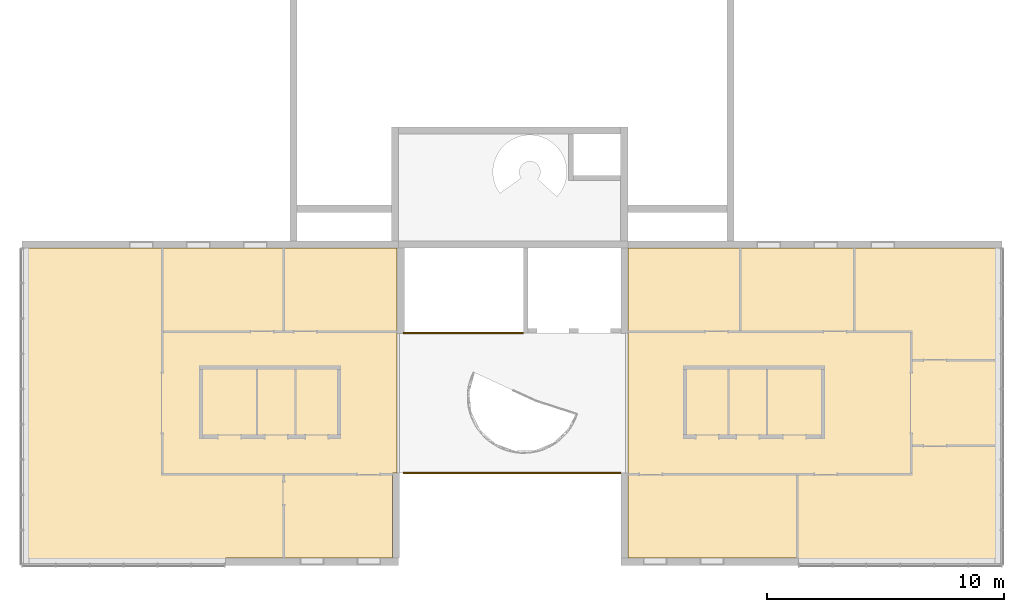
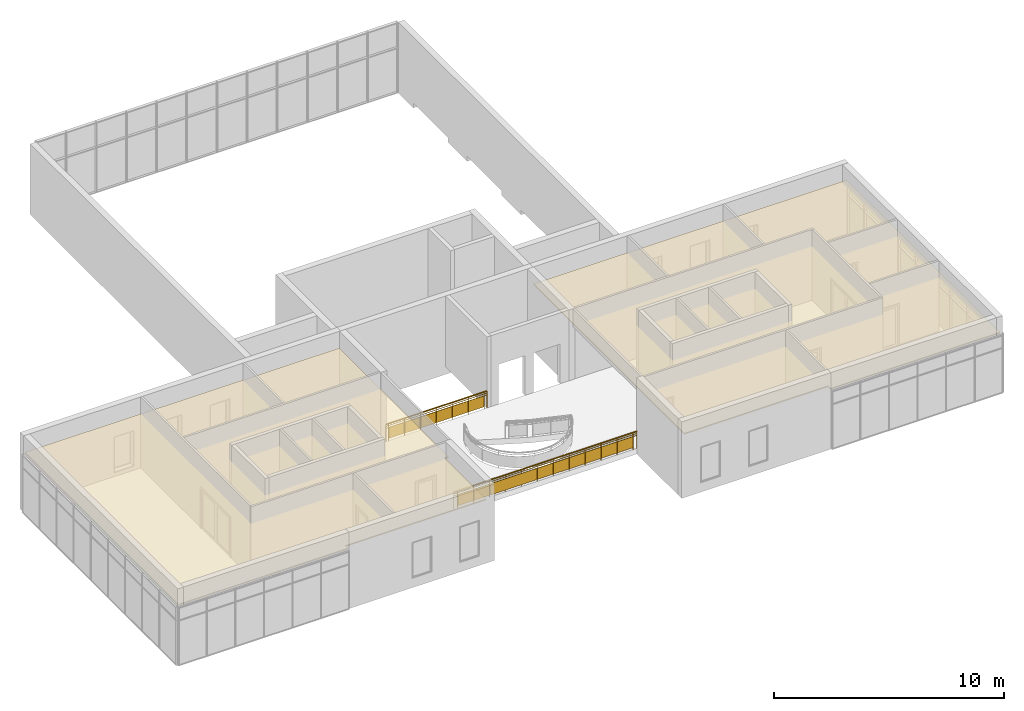
# One storey, part 13 of 13: 2 railings, 1 covering.
"""IFC2X3 building model written with IfcOpenShell, lengths in millimetres."""

from ifc_helpers import new_model, entity, si_unit, converted_unit, derived_unit, direction, frame, frame_2d, origin, place, context, subcontext, project, spatial, polyline, rectangle, outline, extrude, material, material_list, layer, layer_set, layer_usage, element, save


model = new_model("IFC2X3")

# Units and contexts
model_context = context("Model", 3, precision=0.01, world=origin(), true_north=direction((6.12303176911189e-17, 1.0)))
context_of_model = context(None, 3, precision=0.01, world=origin(), true_north=direction((6.12303176911189e-17, 1.0)))
body_context = subcontext(model_context, "Body", "Model", "MODEL_VIEW")
ifc_project = project(units=[si_unit("LENGTHUNIT", "METRE", prefix="MILLI"), si_unit("AREAUNIT", "SQUARE_METRE"), si_unit("VOLUMEUNIT", "CUBIC_METRE"), converted_unit("PLANEANGLEUNIT", "DEGREE", entity("IfcRatioMeasure", 0.0174532925199433), si_unit("PLANEANGLEUNIT", "RADIAN"), dimensions=[0, 0, 0, 0, 0, 0, 0]), si_unit("MASSUNIT", "GRAM", prefix="KILO"), si_unit("TIMEUNIT", "SECOND"), si_unit("FREQUENCYUNIT", "HERTZ"), si_unit("THERMODYNAMICTEMPERATUREUNIT", "DEGREE_CELSIUS"), derived_unit("THERMALTRANSMITTANCEUNIT", [(si_unit("MASSUNIT", "GRAM", prefix="KILO"), 1), (si_unit("THERMODYNAMICTEMPERATUREUNIT", "KELVIN"), -1), (si_unit("TIMEUNIT", "SECOND"), -3)]), derived_unit("VOLUMETRICFLOWRATEUNIT", [(si_unit("LENGTHUNIT", "METRE"), 3), (si_unit("TIMEUNIT", "SECOND"), -1)]), si_unit("ELECTRICCURRENTUNIT", "AMPERE"), si_unit("ELECTRICVOLTAGEUNIT", "VOLT"), si_unit("POWERUNIT", "WATT"), si_unit("FORCEUNIT", "NEWTON", prefix="KILO"), si_unit("ILLUMINANCEUNIT", "LUX"), si_unit("LUMINOUSFLUXUNIT", "LUMEN"), si_unit("LUMINOUSINTENSITYUNIT", "CANDELA"), si_unit("PRESSUREUNIT", "PASCAL")], contexts=[model_context, context_of_model])

# Site, building, storey
site_placement = place(None, origin())
site = spatial("IfcSite", under=ifc_project, at=site_placement, CompositionType="ELEMENT")
building_placement = place(site_placement, origin())
building = spatial("IfcBuilding", under=site, at=building_placement, CompositionType="ELEMENT")
storey_placement = place(building_placement, frame((0.0, 0.0, 3750.0)))
storey = spatial("IfcBuildingStorey", under=building, at=storey_placement, Name="02. 2 etg.", CompositionType="ELEMENT", Elevation=3750.00000000068)

# Covering
ifc_material_1 = material(Name="Metal Stud Layer")
ifc_layer_1 = layer(ifc_material_1, 45.0)
ifc_material_2 = material(Name="Gypsum Wall Board")
ifc_layer_2 = layer(ifc_material_2, 12.0)
ifc_layer_set = layer_set([ifc_layer_1, ifc_layer_2], Name="Compound Ceiling:Plain")
ifc_layer_usage = layer_usage(ifc_layer_set, "AXIS3", "NEGATIVE", 0.0)
covering_placement = place(storey_placement, frame((-165.0, -13365.0, 2800.0)))
element("IfcCovering", 1, at=covering_placement, inside=storey, material=ifc_layer_usage, Name="Compound Ceiling:Plain", ObjectType="Compound Ceiling:Plain", PredefinedType="CEILING", context=body_context, shape_type="SweptSolid", body=[
    extrude(outline(polyline([(-8073.33333333336, -8795.0), (7631.66666666668, -8795.0), (7631.66666666668, 4285.0), (441.666666666662, 4285.0), (441.666666666662, 4510.0), (-8073.33333333336, 4510.0), (-8073.33333333336, -8795.0)])), frame((33114.9023790161, 4510.0, 0.0), z_axis=(0.0, 0.0, 1.0), x_axis=(-1.0, 0.0, 0.0)), (0.0, 0.0, 1.0), 57.0),
    extrude(outline(polyline([(-6906.33333333331, -9423.33333333336), (8848.6666666667, -9423.33333333336), (8848.66666666668, 3656.66666666675), (8848.66666666668, 3881.6666666667), (343.66666666665, 3881.6666666667), (343.666666666652, 3656.6666666667), (-6710.33333333336, 3656.66666666667), (-6710.33333333335, 56.666666666597), (-6906.33333333334, 56.6666666665963), (-6906.33333333331, -9423.33333333336)])), frame((8848.66666666669, 3881.66666666673, 0.0), z_axis=(0.0, 0.0, 1.0), x_axis=(-1.0, 0.0, 0.0)), (0.0, 0.0, 1.0), 57.0),
])

# Railings
ifc_material_3 = material(Name="Metal - Stainless Steel,Polished")
ifc_material_4 = material(Name="Glass")
ifc_material_list_1 = material_list([ifc_material_3, ifc_material_4])
railing_1_placement = place(storey_placement, frame((15836.0, -3690.98603739636, 0.0)))
element("IfcRailing", 2, at=railing_1_placement, inside=storey, material=ifc_material_list_1, Name="Railing:Glass Panel - Bottom Fill", ObjectType="Railing:Glass Panel - Bottom Fill", PredefinedType="NOTDEFINED", context=body_context, shape_type="SweptSolid", body=[
    extrude(rectangle(XDim=50.0, YDim=11.9999999999994, at=frame_2d((2.71782596428238e-13, -1.0831335828243e-12), x_axis=(1.0, 0.0))), frame((140.948313566078, 40.9860373963539, 0.0), z_axis=(0.0, 0.0, 1.0), x_axis=(0.0, 1.0, 0.0)), (0.0, 0.0, 1.0), 869.84653257006),
    extrude(rectangle(XDim=4.99999999999995, YDim=799.999999999998, at=frame_2d((0.0, -1.08002495835535e-12), x_axis=(1.0, 0.0))), frame((540.948313566086, 45.2108474939677, 100.0), z_axis=(0.0, 0.0, 1.0), x_axis=(0.0, 1.0, 0.0)), (0.0, 0.0, 1.0), 580.0),
    extrude(rectangle(XDim=50.0, YDim=11.9999999999994, at=frame_2d((-2.71782596428238e-13, -1.0831335828243e-12), x_axis=(1.0, 0.0))), frame((940.94831356608, 40.9860373963523, 0.0), z_axis=(0.0, 0.0, 1.0), x_axis=(0.0, 1.0, 0.0)), (0.0, 0.0, 1.0), 869.84653257006),
    extrude(rectangle(XDim=4.99999999999995, YDim=799.999999999998, at=frame_2d((0.0, -1.08002495835535e-12), x_axis=(1.0, 0.0))), frame((1340.94831356609, 45.210847493965, 100.0), z_axis=(0.0, 0.0, 1.0), x_axis=(0.0, 1.0, 0.0)), (0.0, 0.0, 1.0), 580.0),
    extrude(rectangle(XDim=50.0, YDim=11.9999999999994, at=frame_2d((2.71782596428238e-13, -1.0831335828243e-12), x_axis=(1.0, 0.0))), frame((1740.94831356608, 40.986037396349, 0.0), z_axis=(0.0, 0.0, 1.0), x_axis=(0.0, 1.0, 0.0)), (0.0, 0.0, 1.0), 869.84653257006),
    extrude(rectangle(XDim=4.99999999999995, YDim=799.999999999998, at=frame_2d((-5.41344746807226e-13, -1.08002495835535e-12), x_axis=(1.0, 0.0))), frame((2140.94831356609, 45.2108474939634, 100.0), z_axis=(0.0, 0.0, 1.0), x_axis=(0.0, 1.0, 0.0)), (0.0, 0.0, 1.0), 580.0),
    extrude(rectangle(XDim=50.0, YDim=11.9999999999994, at=frame_2d((-2.71782596428238e-13, -1.0831335828243e-12), x_axis=(1.0, 0.0))), frame((2540.94831356608, 40.9860373963468, 0.0), z_axis=(0.0, 0.0, 1.0), x_axis=(0.0, 1.0, 0.0)), (0.0, 0.0, 1.0), 869.84653257006),
    extrude(rectangle(XDim=4.99999999999995, YDim=799.999999999998, at=frame_2d((0.0, -1.08002495835535e-12), x_axis=(1.0, 0.0))), frame((2940.94831356609, 45.2108474939602, 100.0), z_axis=(0.0, 0.0, 1.0), x_axis=(0.0, 1.0, 0.0)), (0.0, 0.0, 1.0), 580.0),
    extrude(rectangle(XDim=50.0, YDim=11.9999999999994, at=frame_2d((2.71782596428238e-13, -1.0831335828243e-12), x_axis=(1.0, 0.0))), frame((3340.94831356608, 40.9860373963436, 0.0), z_axis=(0.0, 0.0, 1.0), x_axis=(0.0, 1.0, 0.0)), (0.0, 0.0, 1.0), 869.84653257006),
    extrude(rectangle(XDim=4.99999999999995, YDim=799.999999999998, at=frame_2d((0.0, 2.1600499167107e-12), x_axis=(1.0, 0.0))), frame((3740.94831356609, 45.2108474939574, 100.0), z_axis=(0.0, 0.0, 1.0), x_axis=(0.0, 1.0, 0.0)), (0.0, 0.0, 1.0), 580.0),
    extrude(rectangle(XDim=50.0, YDim=12.0000000000016, at=frame_2d((2.71782596428238e-13, -2.16582307643876e-12), x_axis=(1.0, 0.0))), frame((4140.94831356608, 40.9860373963414, 0.0), z_axis=(0.0, 0.0, 1.0), x_axis=(0.0, 1.0, 0.0)), (0.0, 0.0, 1.0), 869.84653257006),
    extrude(rectangle(XDim=4.99999999999995, YDim=799.999999999996, at=frame_2d((0.0, -2.1600499167107e-12), x_axis=(1.0, 0.0))), frame((4540.94831356609, 45.2108474939547, 100.0), z_axis=(0.0, 0.0, 1.0), x_axis=(0.0, 1.0, 0.0)), (0.0, 0.0, 1.0), 580.0),
    extrude(rectangle(XDim=50.0, YDim=12.0000000000016, at=frame_2d((-2.71782596428238e-13, -2.16582307643876e-12), x_axis=(1.0, 0.0))), frame((4940.94831356608, 40.9860373963393, 0.0), z_axis=(0.0, 0.0, 1.0), x_axis=(0.0, 1.0, 0.0)), (0.0, 0.0, 1.0), 869.84653257006),
    extrude(rectangle(XDim=50.0, YDim=11.9999999999994, at=frame_2d((2.71782596428238e-13, 1.0831335828243e-12), x_axis=(1.0, 0.0))), frame((6.0, 40.9860373963544, 0.0), z_axis=(0.0, 0.0, 1.0), x_axis=(0.0, 1.0, 0.0)), (0.0, 0.0, 1.0), 869.84653257006),
    extrude(rectangle(XDim=50.0, YDim=12.0000000000016, at=frame_2d((2.71782596428238e-13, 2.16582307643876e-12), x_axis=(1.0, 0.0))), frame((5075.89662713217, 40.9860373963382, 0.0), z_axis=(0.0, 0.0, 1.0), x_axis=(0.0, 1.0, 0.0)), (0.0, 0.0, 1.0), 869.84653257006),
    extrude(rectangle(XDim=5073.89662713216, YDim=19.9999999999998, at=frame_2d((-2.04636307898909e-12, 5.40900657597376e-13), x_axis=(1.0, 0.0))), frame((2540.94831356609, 40.9860373963512, 780.0), z_axis=(0.0, 0.0, 1.0), x_axis=(-1.0, 0.0, 0.0)), (0.0, 0.0, 1.0), 19.9999999999998),
    extrude(rectangle(XDim=5073.89662713216, YDim=19.9999999999998, at=frame_2d((-2.04636307898909e-12, 5.40900657597376e-13), x_axis=(1.0, 0.0))), frame((2540.94831356609, 40.9860373963512, 680.0), z_axis=(0.0, 0.0, 1.0), x_axis=(-1.0, 0.0, 0.0)), (0.0, 0.0, 1.0), 19.9999999999998),
    extrude(outline(polyline([(-10.9067895099423, -38.484307744661), (1.77588559309788, -38.4843077446611), (14.1514939436774, -31.8300213166493), (24.0801804291089, -19.6720350363233), (29.8451849567756, -4.11257518338867), (30.4496858704227, 12.1579862803262), (25.7891594703618, 26.3263214643352), (16.6694531107169, 35.9425965000385), (10.9067895099426, 38.4843077446621), (-1.77588559309758, 38.4843077446621), (-14.1514939436772, 31.8300213166503), (-24.0801804291086, 19.6720350363243), (-29.8451849567753, 4.11257518338971), (-30.4496858704224, -12.1579862803252), (-25.7891594703615, -26.3263214643342), (-16.6694531107166, -35.9425965000375), (-10.9067895099423, -38.484307744661)])), frame((4.0, 41.5952722359328, 900.0), z_axis=(1.0, 0.0, 0.0), x_axis=(0.0, -0.27266973774856, 0.962107693616537)), (0.0, 0.0, 1.0), 5073.89662713216),
])
ifc_material_list_2 = material_list([ifc_material_3, ifc_material_4])
railing_2_placement = place(storey_placement, frame((15836.0, -9592.20450707549, 0.0)))
element("IfcRailing", 3, at=railing_2_placement, inside=storey, material=ifc_material_list_2, Name="Railing:Glass Panel - Bottom Fill", ObjectType="Railing:Glass Panel - Bottom Fill", PredefinedType="NOTDEFINED", context=body_context, shape_type="SweptSolid", body=[
    extrude(rectangle(XDim=49.9999999999995, YDim=12.0000000000016, at=frame_2d((-5.41788836017076e-13, -2.16582307643876e-12), x_axis=(1.0, 0.0))), frame((8993.11785617472, 42.2045070754944, 0.0), z_axis=(0.0, 0.0, 1.0), x_axis=(0.0, -1.0, 0.0)), (0.0, 0.0, 1.0), 869.84653257006),
    extrude(rectangle(XDim=4.99999999999995, YDim=799.999999999996, at=frame_2d((5.41344746807226e-13, -2.1600499167107e-12), x_axis=(1.0, 0.0))), frame((8593.11785617472, 37.9796969778822, 100.0), z_axis=(0.0, 0.0, 1.0), x_axis=(0.0, -1.0, 0.0)), (0.0, 0.0, 1.0), 580.0),
    extrude(rectangle(XDim=49.9999999999995, YDim=12.0000000000016, at=frame_2d((5.41788836017076e-13, -2.16582307643876e-12), x_axis=(1.0, 0.0))), frame((8193.11785617472, 42.2045070754976, 0.0), z_axis=(0.0, 0.0, 1.0), x_axis=(0.0, -1.0, 0.0)), (0.0, 0.0, 1.0), 869.84653257006),
    extrude(rectangle(XDim=4.99999999999995, YDim=799.999999999996, at=frame_2d((-5.41344746807226e-13, -2.1600499167107e-12), x_axis=(1.0, 0.0))), frame((7793.11785617472, 37.9796969778832, 100.0), z_axis=(0.0, 0.0, 1.0), x_axis=(0.0, -1.0, 0.0)), (0.0, 0.0, 1.0), 580.0),
    extrude(rectangle(XDim=49.9999999999995, YDim=12.0000000000016, at=frame_2d((5.41788836017076e-13, -2.16582307643876e-12), x_axis=(1.0, 0.0))), frame((7393.11785617472, 42.2045070754998, 0.0), z_axis=(0.0, 0.0, 1.0), x_axis=(0.0, -1.0, 0.0)), (0.0, 0.0, 1.0), 869.84653257006),
    extrude(rectangle(XDim=4.99999999999995, YDim=799.999999999996, at=frame_2d((5.41344746807226e-13, -2.1600499167107e-12), x_axis=(1.0, 0.0))), frame((6993.11785617472, 37.9796969778865, 100.0), z_axis=(0.0, 0.0, 1.0), x_axis=(0.0, -1.0, 0.0)), (0.0, 0.0, 1.0), 580.0),
    extrude(rectangle(XDim=49.9999999999995, YDim=12.0000000000016, at=frame_2d((0.0, -2.16582307643876e-12), x_axis=(1.0, 0.0))), frame((6593.11785617472, 42.2045070755031, 0.0), z_axis=(0.0, 0.0, 1.0), x_axis=(0.0, -1.0, 0.0)), (0.0, 0.0, 1.0), 869.84653257006),
    extrude(rectangle(XDim=4.99999999999995, YDim=799.999999999996, at=frame_2d((-5.41344746807226e-13, -2.1600499167107e-12), x_axis=(1.0, 0.0))), frame((6193.11785617472, 37.9796969778887, 100.0), z_axis=(0.0, 0.0, 1.0), x_axis=(0.0, -1.0, 0.0)), (0.0, 0.0, 1.0), 580.0),
    extrude(rectangle(XDim=49.9999999999995, YDim=12.0000000000016, at=frame_2d((1.08357767203415e-12, -2.16582307643876e-12), x_axis=(1.0, 0.0))), frame((5793.11785617472, 42.2045070755063, 0.0), z_axis=(0.0, 0.0, 1.0), x_axis=(0.0, -1.0, 0.0)), (0.0, 0.0, 1.0), 869.84653257006),
    extrude(rectangle(XDim=4.99999999999995, YDim=799.999999999996, at=frame_2d((-5.41344746807226e-13, -2.1600499167107e-12), x_axis=(1.0, 0.0))), frame((5393.11785617472, 37.9796969778908, 100.0), z_axis=(0.0, 0.0, 1.0), x_axis=(0.0, -1.0, 0.0)), (0.0, 0.0, 1.0), 580.0),
    extrude(rectangle(XDim=49.9999999999995, YDim=12.0000000000016, at=frame_2d((0.0, -2.16582307643876e-12), x_axis=(1.0, 0.0))), frame((4993.11785617472, 42.2045070755074, 0.0), z_axis=(0.0, 0.0, 1.0), x_axis=(0.0, -1.0, 0.0)), (0.0, 0.0, 1.0), 869.84653257006),
    extrude(rectangle(XDim=4.99999999999995, YDim=799.999999999996, at=frame_2d((5.41344746807226e-13, -2.1600499167107e-12), x_axis=(1.0, 0.0))), frame((4593.11785617472, 37.9796969778952, 100.0), z_axis=(0.0, 0.0, 1.0), x_axis=(0.0, -1.0, 0.0)), (0.0, 0.0, 1.0), 580.0),
    extrude(rectangle(XDim=49.9999999999995, YDim=12.0000000000016, at=frame_2d((5.41788836017076e-13, -2.16582307643876e-12), x_axis=(1.0, 0.0))), frame((4193.11785617472, 42.2045070755106, 0.0), z_axis=(0.0, 0.0, 1.0), x_axis=(0.0, -1.0, 0.0)), (0.0, 0.0, 1.0), 869.84653257006),
    extrude(rectangle(XDim=4.99999999999995, YDim=799.999999999998, at=frame_2d((-5.41344746807226e-13, 1.08002495835535e-12), x_axis=(1.0, 0.0))), frame((3793.11785617472, 37.9796969778962, 100.0), z_axis=(0.0, 0.0, 1.0), x_axis=(0.0, -1.0, 0.0)), (0.0, 0.0, 1.0), 580.0),
    extrude(rectangle(XDim=49.9999999999995, YDim=11.9999999999994, at=frame_2d((-5.41788836017076e-13, -1.0831335828243e-12), x_axis=(1.0, 0.0))), frame((3393.11785617472, 42.2045070755117, 0.0), z_axis=(0.0, 0.0, 1.0), x_axis=(0.0, -1.0, 0.0)), (0.0, 0.0, 1.0), 869.84653257006),
    extrude(rectangle(XDim=4.99999999999995, YDim=799.999999999998, at=frame_2d((5.41344746807226e-13, -1.08002495835535e-12), x_axis=(1.0, 0.0))), frame((2993.11785617472, 37.9796969778995, 100.0), z_axis=(0.0, 0.0, 1.0), x_axis=(0.0, -1.0, 0.0)), (0.0, 0.0, 1.0), 580.0),
    extrude(rectangle(XDim=49.9999999999995, YDim=11.9999999999994, at=frame_2d((5.41788836017076e-13, 1.0831335828243e-12), x_axis=(1.0, 0.0))), frame((2593.11785617472, 42.204507075515, 0.0), z_axis=(0.0, 0.0, 1.0), x_axis=(0.0, -1.0, 0.0)), (0.0, 0.0, 1.0), 869.84653257006),
    extrude(rectangle(XDim=4.99999999999995, YDim=799.999999999998, at=frame_2d((5.41344746807226e-13, 1.08002495835535e-12), x_axis=(1.0, 0.0))), frame((2193.11785617472, 37.9796969779027, 100.0), z_axis=(0.0, 0.0, 1.0), x_axis=(0.0, -1.0, 0.0)), (0.0, 0.0, 1.0), 580.0),
    extrude(rectangle(XDim=49.9999999999995, YDim=11.9999999999994, at=frame_2d((-1.08357767203415e-12, -1.0831335828243e-12), x_axis=(1.0, 0.0))), frame((1793.11785617472, 42.2045070755171, 0.0), z_axis=(0.0, 0.0, 1.0), x_axis=(0.0, -1.0, 0.0)), (0.0, 0.0, 1.0), 869.84653257006),
    extrude(rectangle(XDim=4.99999999999995, YDim=799.999999999998, at=frame_2d((-5.41344746807226e-13, -1.08002495835535e-12), x_axis=(1.0, 0.0))), frame((1393.11785617472, 37.9796969779038, 100.0), z_axis=(0.0, 0.0, 1.0), x_axis=(0.0, -1.0, 0.0)), (0.0, 0.0, 1.0), 580.0),
    extrude(rectangle(XDim=49.9999999999995, YDim=11.9999999999994, at=frame_2d((0.0, 1.0831335828243e-12), x_axis=(1.0, 0.0))), frame((993.117856174721, 42.2045070755204, 0.0), z_axis=(0.0, 0.0, 1.0), x_axis=(0.0, -1.0, 0.0)), (0.0, 0.0, 1.0), 869.84653257006),
    extrude(rectangle(XDim=4.99999999999995, YDim=799.999999999998, at=frame_2d((-5.41344746807226e-13, 1.08002495835535e-12), x_axis=(1.0, 0.0))), frame((593.117856174715, 37.979696977906, 100.0), z_axis=(0.0, 0.0, 1.0), x_axis=(0.0, -1.0, 0.0)), (0.0, 0.0, 1.0), 580.0),
    extrude(rectangle(XDim=49.9999999999995, YDim=11.9999999999994, at=frame_2d((1.08357767203415e-12, -1.0831335828243e-12), x_axis=(1.0, 0.0))), frame((193.117856174724, 42.2045070755236, 0.0), z_axis=(0.0, 0.0, 1.0), x_axis=(0.0, -1.0, 0.0)), (0.0, 0.0, 1.0), 869.84653257006),
    extrude(rectangle(XDim=49.9999999999995, YDim=12.0000000000016, at=frame_2d((0.0, -2.16582307643876e-12), x_axis=(1.0, 0.0))), frame((9180.23571234944, 42.2045070754944, 0.0), z_axis=(0.0, 0.0, 1.0), x_axis=(0.0, -1.0, 0.0)), (0.0, 0.0, 1.0), 869.84653257006),
    extrude(rectangle(XDim=49.9999999999995, YDim=11.9999999999994, at=frame_2d((5.41788836017076e-13, -1.0831335828243e-12), x_axis=(1.0, 0.0))), frame((6.0, 42.2045070755236, 0.0), z_axis=(0.0, 0.0, 1.0), x_axis=(0.0, -1.0, 0.0)), (0.0, 0.0, 1.0), 869.84653257006),
    extrude(rectangle(XDim=9178.23571234944, YDim=19.9999999999998, at=frame_2d((-1.36424205265939e-12, 5.40900657597376e-13), x_axis=(1.0, 0.0))), frame((4593.11785617472, 42.2045070755041, 780.0)), (0.0, 0.0, 1.0), 19.9999999999998),
    extrude(rectangle(XDim=9178.23571234944, YDim=19.9999999999998, at=frame_2d((-1.36424205265939e-12, 5.40900657597376e-13), x_axis=(1.0, 0.0))), frame((4593.11785617472, 42.2045070755041, 680.0)), (0.0, 0.0, 1.0), 19.9999999999998),
    extrude(outline(polyline([(-10.9067895099413, -38.4843077446613), (1.77588559309937, -38.4843077446613), (14.1514939436783, -31.8300213166493), (24.0801804291095, -19.6720350363237), (29.8451849567762, -4.11257518338846), (30.4496858704229, 12.1579862803259), (25.7891594703619, 26.3263214643349), (16.6694531107162, 35.9425965000377), (10.9067895099424, 38.484307744661), (-1.77588559309751, 38.4843077446619), (-14.1514939436773, 31.830021316649), (-24.0801804291084, 19.6720350363234), (-29.8451849567751, 4.11257518338817), (-30.4496858704219, -12.1579862803262), (-25.7891594703609, -26.3263214643352), (-16.6694531107157, -35.9425965000378), (-10.9067895099413, -38.4843077446613)])), frame((4.0, 41.5952722359458, 900.0), z_axis=(1.0, 0.0, 0.0), x_axis=(0.0, 0.272669737748549, -0.96210769361654)), (0.0, 0.0, 1.0), 9178.23571234944),
])

save(model, "model.ifc")
